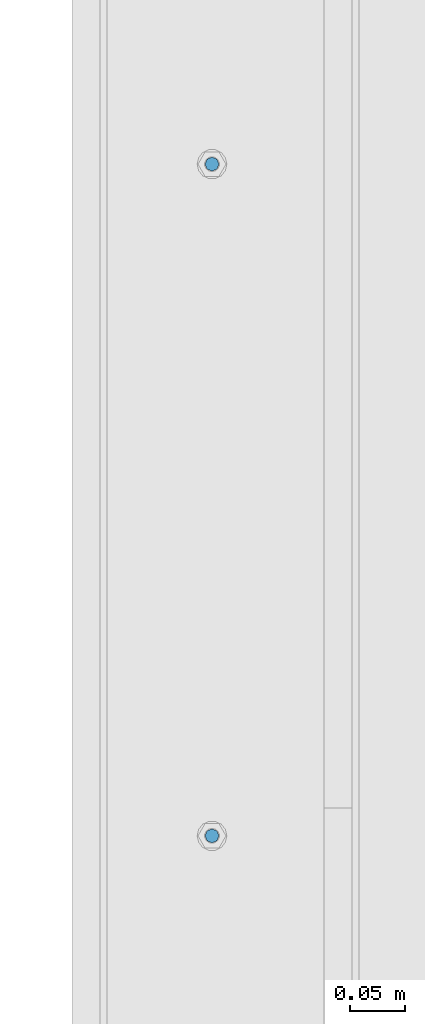
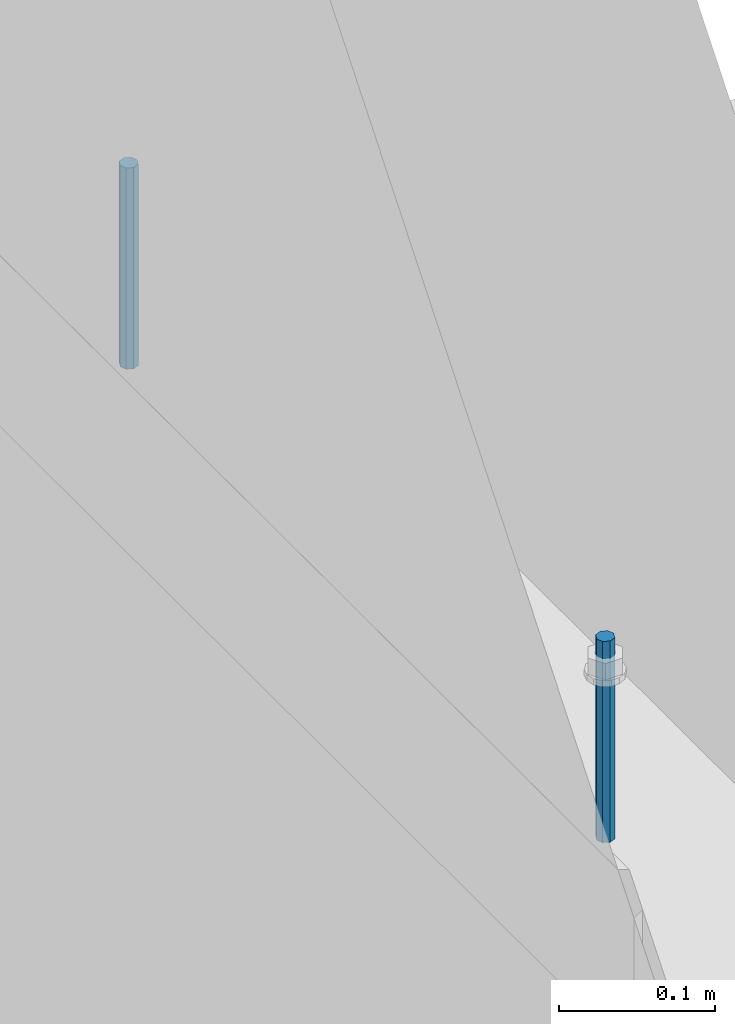
# One storey, part 391 of 1179: 2 columns, 1 element without a shape of its own.
"""IFC2X3 building model written with IfcOpenShell, lengths in millimetres."""

from ifc_helpers import new_model, si_unit, frame, origin_with_axes, place, context, subcontext, project, spatial, faceted_brep, material, type_object, element, aggregate, save


model = new_model("IFC2X3")

# Units and contexts
model_context = context("Model", 3, precision=1e-05, world=origin_with_axes())
body_context = subcontext(model_context, "Body", "Model", "MODEL_VIEW")
ifc_project = project(units=[si_unit("LENGTHUNIT", "METRE", prefix="MILLI"), si_unit("AREAUNIT", "SQUARE_METRE"), si_unit("VOLUMEUNIT", "CUBIC_METRE"), si_unit("MASSUNIT", "GRAM", prefix="KILO"), si_unit("TIMEUNIT", "SECOND"), si_unit("PLANEANGLEUNIT", "RADIAN"), si_unit("SOLIDANGLEUNIT", "STERADIAN"), si_unit("THERMODYNAMICTEMPERATUREUNIT", "DEGREE_CELSIUS"), si_unit("LUMINOUSINTENSITYUNIT", "LUMEN")], contexts=[model_context])

# Site, building, storey
site_placement = place(None, origin_with_axes())
site = spatial("IfcSite", under=ifc_project, at=site_placement, CompositionType="ELEMENT")
building_placement = place(site_placement, origin_with_axes())
building = spatial("IfcBuilding", under=site, at=building_placement, Name="Undefined", CompositionType="ELEMENT")
storey_placement = place(building_placement, origin_with_axes())
storey = spatial("IfcBuildingStorey", under=building, at=storey_placement, Name="Undefined", CompositionType="ELEMENT", Elevation=0.0)

# Assembly, columns
assembly_placement = place(storey_placement, origin_with_axes())
assembly = element("IfcElementAssembly", 1, at=assembly_placement, inside=storey, Name="BEAM", AssemblyPlace="NOTDEFINED", PredefinedType="RIGID_FRAME")
ifc_material = material(Name="STEEL/A307")
column_type = type_object("IfcColumnType", PredefinedType="NOTDEFINED")
column_1_placement = place(assembly_placement, frame((101.599999999999, 15354.3, 4108.45), z_axis=(0.0, 1.0, 0.0), x_axis=(0.0, 0.0, 1.0)))
column_1 = element("IfcColumn", 2, at=column_1_placement, type_object=column_type, material=ifc_material, Name="THREADED ROD", context=body_context, shape_type="Brep", body=[
    faceted_brep([(0.0, -6.34999999999854, 0.0), (0.0, -4.49012806053361, -4.49012806053452), (157.162499999999, -4.49012806053361, -4.49012806053361), (157.162499999999, -6.34999999999854, 0.0), (0.0, 0.0, -6.34999999999991), (157.162499999999, 0.0, -6.34999999999854), (0.0, 4.49012806053361, -4.49012806053452), (157.162499999999, 4.49012806053361, -4.49012806053361), (0.0, 6.34999999999854, 0.0), (157.162499999999, 6.34999999999854, 0.0), (0.0, 4.49012806053361, 4.49012806053452), (157.162499999999, 4.49012806053361, 4.49012806053361), (0.0, 0.0, 6.34999999999991), (157.162499999999, 0.0, 6.34999999999854), (0.0, -4.49012806053361, 4.49012806053452), (157.162499999999, -4.49012806053361, 4.49012806053361)], [[[0, 1, 2, 3]], [[1, 4, 5, 2]], [[4, 6, 7, 5]], [[6, 8, 9, 7]], [[8, 10, 11, 9]], [[10, 12, 13, 11]], [[12, 14, 15, 13]], [[14, 0, 3, 15]], [[5, 7, 9, 11, 13, 15, 3, 2]], [[14, 12, 10, 8, 6, 4, 1, 0]]]),
])
column_2_placement = place(assembly_placement, frame((101.599999999999, 14744.7, 4108.45), z_axis=(0.0, 1.0, 0.0), x_axis=(0.0, 0.0, 1.0)))
column_2 = element("IfcColumn", 3, at=column_2_placement, type_object=column_type, material=ifc_material, Name="THREADED ROD", context=body_context, shape_type="Brep", body=[
    faceted_brep([(0.0, -6.34999999999854, 0.0), (0.0, -4.49012806053361, -4.49012806053452), (157.162499999999, -4.49012806053361, -4.49012806053361), (157.162499999999, -6.34999999999854, 0.0), (0.0, 0.0, -6.34999999999991), (157.162499999999, 0.0, -6.34999999999854), (0.0, 4.49012806053361, -4.49012806053452), (157.162499999999, 4.49012806053361, -4.49012806053361), (0.0, 6.34999999999854, 0.0), (157.162499999999, 6.34999999999854, 0.0), (0.0, 4.49012806053361, 4.49012806053452), (157.162499999999, 4.49012806053361, 4.49012806053361), (0.0, 0.0, 6.34999999999991), (157.162499999999, 0.0, 6.34999999999854), (0.0, -4.49012806053361, 4.49012806053452), (157.162499999999, -4.49012806053361, 4.49012806053361)], [[[0, 1, 2, 3]], [[1, 4, 5, 2]], [[4, 6, 7, 5]], [[6, 8, 9, 7]], [[8, 10, 11, 9]], [[10, 12, 13, 11]], [[12, 14, 15, 13]], [[14, 0, 3, 15]], [[5, 7, 9, 11, 13, 15, 3, 2]], [[14, 12, 10, 8, 6, 4, 1, 0]]]),
])
aggregate(assembly, [column_1, column_2])

save(model, "model.ifc")
